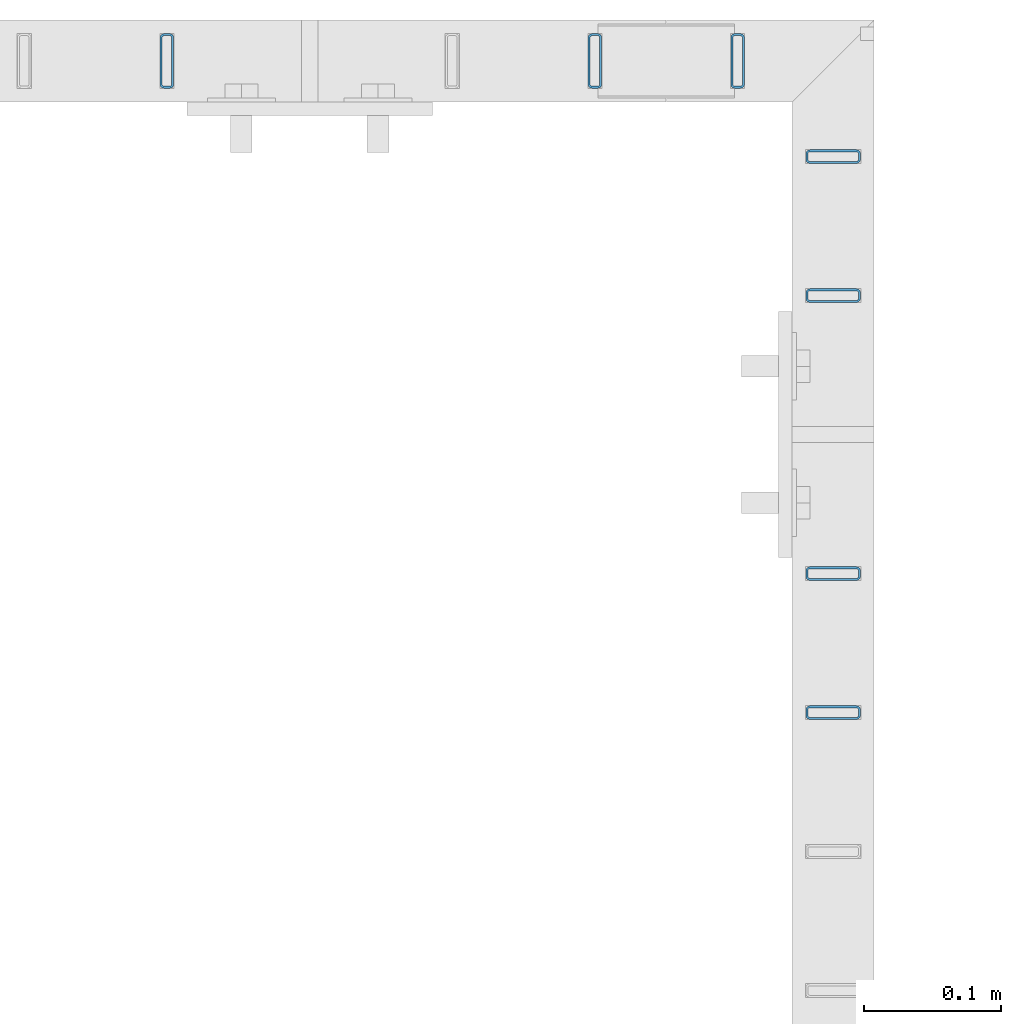
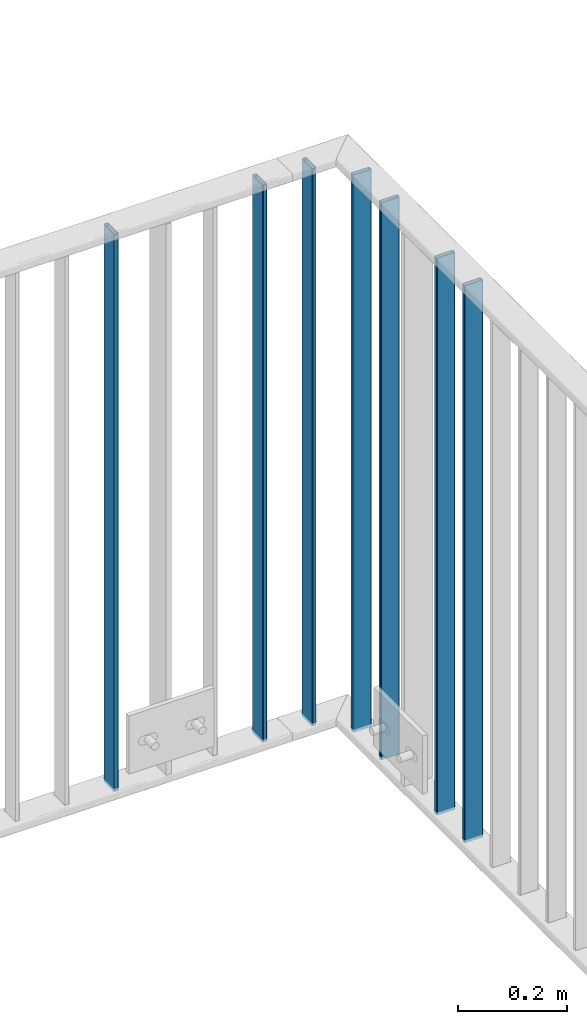
# One storey, part 13 of 156: 7 beams, 2 elements without a shape of their own.
"""IFC2X3 building model written with IfcOpenShell, lengths in millimetres."""

from ifc_helpers import new_model, si_unit, frame, origin_with_axes, origin_2d_with_axis, place, context, subcontext, project, spatial, hollow_rectangle, extrude, clip, halfspace, material, type_object, element, aggregate, save


model = new_model("IFC2X3")

# Units and contexts
model_context = context("Model", 3, precision=1e-05, world=origin_with_axes())
body_context = subcontext(model_context, "Body", "Model", "MODEL_VIEW")
ifc_project = project(units=[si_unit("LENGTHUNIT", "METRE", prefix="MILLI"), si_unit("AREAUNIT", "SQUARE_METRE"), si_unit("VOLUMEUNIT", "CUBIC_METRE"), si_unit("MASSUNIT", "GRAM", prefix="KILO"), si_unit("TIMEUNIT", "SECOND"), si_unit("PLANEANGLEUNIT", "RADIAN"), si_unit("SOLIDANGLEUNIT", "STERADIAN"), si_unit("THERMODYNAMICTEMPERATUREUNIT", "DEGREE_CELSIUS"), si_unit("LUMINOUSINTENSITYUNIT", "LUMEN")], contexts=[model_context])

# Site, building, storey
site_placement = place(None, origin_with_axes())
site = spatial("IfcSite", under=ifc_project, at=site_placement, CompositionType="ELEMENT")
building_placement = place(site_placement, origin_with_axes())
building = spatial("IfcBuilding", under=site, at=building_placement, Name="Undefined", CompositionType="ELEMENT")
storey_placement = place(building_placement, origin_with_axes())
storey = spatial("IfcBuildingStorey", under=building, at=storey_placement, Name="Undefined", CompositionType="ELEMENT", Elevation=0.0)

# Assembly, beams
assembly_1_placement = place(storey_placement, origin_with_axes())
assembly_1 = element("IfcElementAssembly", 1, at=assembly_1_placement, inside=storey, AssemblyPlace="NOTDEFINED", PredefinedType="RIGID_FRAME")
ifc_material = material(Name="STEEL/S235JR")
beam_type = type_object("IfcBeamType", Name="K40/10/1.5", PredefinedType="NOTDEFINED")
beam_1_placement = place(assembly_1_placement, frame((17325.0016402503, 23580.8703835168, 3980.00000000003), z_axis=(-1.0, 0.0, 0.0), x_axis=(0.0, 0.0, -1.0)))
beam_1 = element("IfcBeam", 2, at=beam_1_placement, type_object=beam_type, material=ifc_material, ObjectType="K40/10/1.5", context=body_context, shape_type="Clipping", body=[
    clip(clip(extrude(hollow_rectangle(XDim=10.0, YDim=40.0, WallThickness=1.5, InnerFilletRadius=1.5, OuterFilletRadius=3.0, at=origin_2d_with_axis()), frame((1237.00000000003, 0.0, 0.0), z_axis=(-1.0, 0.0, 0.0), x_axis=(0.0, -1.0, 0.0)), (0.0, 0.0, 1.0), 1244.0), halfspace(frame((1237.00000000003, 4.08341515816937, 47.1651964219418), z_axis=(1.0, 0.0, 0.0), x_axis=(0.0, -0.763991285051099, -0.645226562043109)), False)), halfspace(frame((-6.99999999997453, -4.08341515816574, 47.1651964219527), z_axis=(-1.0, 0.0, 0.0), x_axis=(0.0, 0.763991285051099, -0.645226562043109)), False)),
])
beam_2_placement = place(assembly_1_placement, frame((17325.0016402503, 23682.6503835168, 3980.00000000003), z_axis=(-1.0, 0.0, 0.0), x_axis=(0.0, 0.0, -1.0)))
beam_2 = element("IfcBeam", 3, at=beam_2_placement, type_object=beam_type, material=ifc_material, ObjectType="K40/10/1.5", context=body_context, shape_type="Clipping", body=[
    clip(clip(extrude(hollow_rectangle(XDim=10.0, YDim=40.0, WallThickness=1.5, InnerFilletRadius=1.5, OuterFilletRadius=3.0, at=origin_2d_with_axis()), frame((1237.00000000003, 0.0, 0.0), z_axis=(-1.0, 0.0, 0.0), x_axis=(0.0, -1.0, 0.0)), (0.0, 0.0, 1.0), 1244.0), halfspace(frame((1237.00000000003, 4.08341515816937, 47.1651964219418), z_axis=(1.0, 0.0, 0.0), x_axis=(0.0, -0.763991285051099, -0.645226562043109)), False)), halfspace(frame((-6.99999999997453, -4.08341515816574, 47.1651964219527), z_axis=(-1.0, 0.0, 0.0), x_axis=(0.0, 0.763991285051099, -0.645226562043109)), False)),
])
beam_3_placement = place(assembly_1_placement, frame((17325.0016402503, 23886.2103835168, 3980.00000000003), z_axis=(-1.0, 0.0, 0.0), x_axis=(0.0, 0.0, -1.0)))
beam_3 = element("IfcBeam", 4, at=beam_3_placement, type_object=beam_type, material=ifc_material, ObjectType="K40/10/1.5", context=body_context, shape_type="Clipping", body=[
    clip(clip(extrude(hollow_rectangle(XDim=10.0, YDim=40.0, WallThickness=1.5, InnerFilletRadius=1.5, OuterFilletRadius=3.0, at=origin_2d_with_axis()), frame((1237.00000000003, 0.0, 0.0), z_axis=(-1.0, 0.0, 0.0), x_axis=(0.0, -1.0, 0.0)), (0.0, 0.0, 1.0), 1244.0), halfspace(frame((1237.00000000003, 3.90376720472705, 47.0154897941684), z_axis=(1.0, 0.0, 0.0), x_axis=(0.0, -0.761952806119621, -0.647632551101653)), False)), halfspace(frame((-6.99999999997453, -3.90376720472705, 47.0154897941757), z_axis=(-1.0, 0.0, 0.0), x_axis=(0.0, 0.761952806119621, -0.647632551101653)), False)),
])
beam_4_placement = place(assembly_1_placement, frame((17255.001953125, 24057.9916132584, 3980.00000000003), z_axis=(0.0, -1.0, 0.0), x_axis=(0.0, 0.0, -1.0)))
beam_4 = element("IfcBeam", 5, at=beam_4_placement, type_object=beam_type, material=ifc_material, ObjectType="K40/10/1.5", context=body_context, shape_type="Clipping", body=[
    clip(clip(extrude(hollow_rectangle(XDim=10.0, YDim=40.0, WallThickness=1.5, InnerFilletRadius=1.5, OuterFilletRadius=3.0, at=origin_2d_with_axis()), frame((1237.00000000003, 0.0, 0.0), z_axis=(-1.0, 0.0, 0.0), x_axis=(0.0, -1.0, 0.0)), (0.0, 0.0, 1.0), 1244.0), halfspace(frame((1237.00000000003, 4.34248751949781, 47.3810900558092), z_axis=(1.0, 0.0, 0.0), x_axis=(0.0, -0.768354814194188, -0.640024124158313)), False)), halfspace(frame((-6.99999999997453, -4.34248751950508, 47.3810900558092), z_axis=(-1.0, 0.0, 0.0), x_axis=(0.0, 0.7683548141934, -0.640024124159258)), False)),
])
beam_5_placement = place(assembly_1_placement, frame((17325.0016402503, 23987.9903835168, 3980.00000000003), z_axis=(-1.0, 0.0, 0.0), x_axis=(0.0, 0.0, -1.0)))
beam_5 = element("IfcBeam", 6, at=beam_5_placement, type_object=beam_type, material=ifc_material, ObjectType="K40/10/1.5", context=body_context, shape_type="Clipping", body=[
    clip(clip(extrude(hollow_rectangle(XDim=10.0, YDim=40.0, WallThickness=1.5, InnerFilletRadius=1.5, OuterFilletRadius=3.0, at=origin_2d_with_axis()), frame((1237.00000000003, 0.0, 0.0), z_axis=(-1.0, 0.0, 0.0), x_axis=(0.0, -1.0, 0.0)), (0.0, 0.0, 1.0), 1244.0), halfspace(frame((1237.00000000003, 2.66359292875859, 45.9820112315028), z_axis=(1.0, 0.0, 0.0), x_axis=(0.0, -0.747680594278991, -0.664058528247785)), False)), halfspace(frame((-6.99999999997453, -2.66359292875859, 45.9820112315028), z_axis=(-1.0, 0.0, 0.0), x_axis=(0.0, 0.747680594279002, -0.664058528247773)), False)),
])
aggregate(assembly_1, [beam_1, beam_2, beam_3, beam_4, beam_5])

assembly_2_placement = place(storey_placement, origin_with_axes())
assembly_2 = element("IfcElementAssembly", 7, at=assembly_2_placement, inside=storey, AssemblyPlace="NOTDEFINED", PredefinedType="RIGID_FRAME")
beam_6_placement = place(assembly_2_placement, frame((16837.1185961914, 24057.9916132584, 3980.00000000003), z_axis=(0.0, -1.0, 0.0), x_axis=(0.0, 0.0, -1.0)))
beam_6 = element("IfcBeam", 8, at=beam_6_placement, type_object=beam_type, material=ifc_material, ObjectType="K40/10/1.5", context=body_context, shape_type="Clipping", body=[
    clip(clip(extrude(hollow_rectangle(XDim=10.0, YDim=40.0, WallThickness=1.5, InnerFilletRadius=1.5, OuterFilletRadius=3.0, at=origin_2d_with_axis()), frame((1237.00000000003, 0.0, 0.0), z_axis=(-1.0, 0.0, 0.0), x_axis=(0.0, -1.0, 0.0)), (0.0, 0.0, 1.0), 1244.0), halfspace(frame((1237.00000000003, 4.34248751949781, 47.3810900558092), z_axis=(1.0, 0.0, 0.0), x_axis=(0.0, -0.768354814194188, -0.640024124158313)), False)), halfspace(frame((-6.99999999997453, -4.34248751950508, 47.3810900558092), z_axis=(-1.0, 0.0, 0.0), x_axis=(0.0, 0.7683548141934, -0.640024124159258)), False)),
])
beam_7_placement = place(assembly_2_placement, frame((17150.5285961914, 24057.9916132584, 3980.00000000003), z_axis=(0.0, -1.0, 0.0), x_axis=(0.0, 0.0, -1.0)))
beam_7 = element("IfcBeam", 9, at=beam_7_placement, type_object=beam_type, material=ifc_material, ObjectType="K40/10/1.5", context=body_context, shape_type="Clipping", body=[
    clip(clip(extrude(hollow_rectangle(XDim=10.0, YDim=40.0, WallThickness=1.5, InnerFilletRadius=1.5, OuterFilletRadius=3.0, at=origin_2d_with_axis()), frame((1237.00000000003, 0.0, 0.0), z_axis=(-1.0, 0.0, 0.0), x_axis=(0.0, -1.0, 0.0)), (0.0, 0.0, 1.0), 1244.0), halfspace(frame((1237.00000000003, 4.28697690345871, 47.3348312091512), z_axis=(1.0, 0.0, 0.0), x_axis=(0.0, -0.763991285051099, -0.645226562043109)), False)), halfspace(frame((-6.99999999997453, -4.28697690345871, 47.3348312091512), z_axis=(-1.0, 0.0, 0.0), x_axis=(0.0, 0.763991285051099, -0.645226562043109)), False)),
])
aggregate(assembly_2, [beam_6, beam_7])

save(model, "model.ifc")
